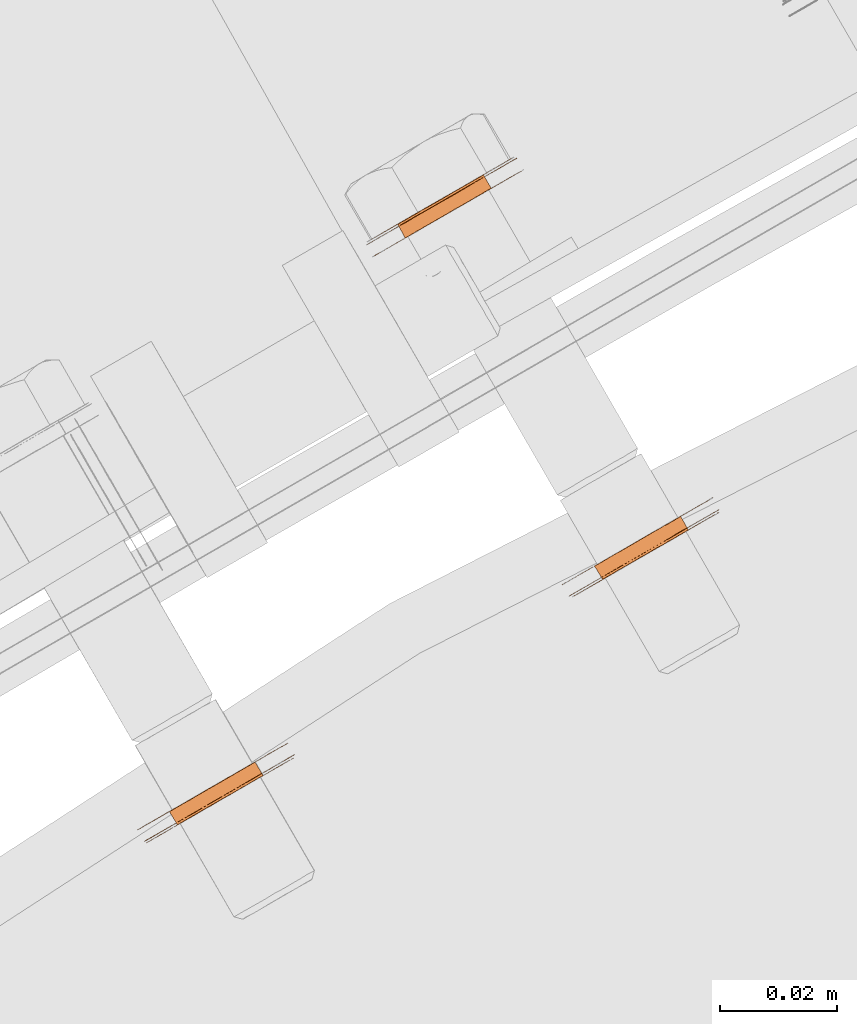
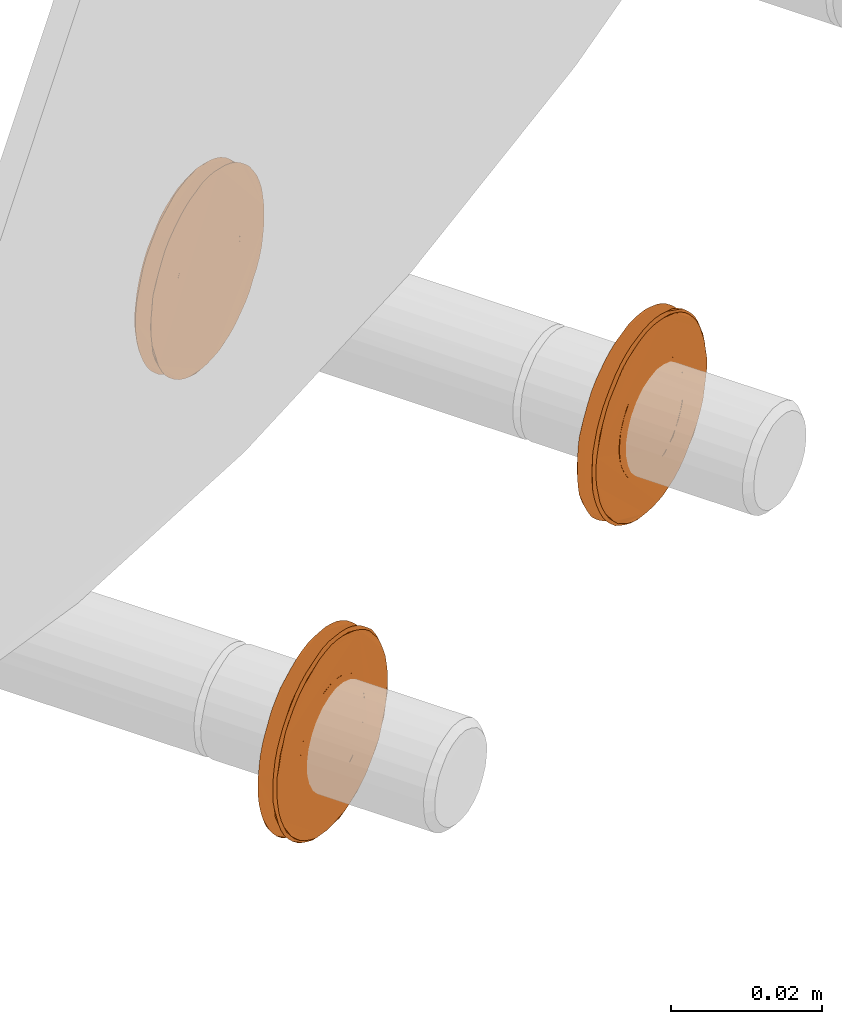
# One storey, part 112 of 126: 3 proxies.
"""IFC2X3 building model written with IfcOpenShell, lengths in millimetres."""

from ifc_helpers import new_model, si_unit, origin, origin_with_axes, place, context, project, spatial, faceted_brep, material, element, save


model = new_model("IFC2X3")

# Units and contexts
context_of_model_1 = context(None, 3, precision=0.1, world=origin())
context_of_model_2 = context(None, 3, precision=0.1, world=origin())
ifc_project = project(units=[si_unit("LENGTHUNIT", "METRE", prefix="MILLI"), si_unit("AREAUNIT", "SQUARE_METRE", prefix="CENTI"), si_unit("VOLUMEUNIT", "CUBIC_METRE", prefix="CENTI"), si_unit("MASSUNIT", "GRAM", prefix="KILO")], contexts=[context_of_model_1, context_of_model_2])

# Site, building, storey
site_placement = place(None, origin_with_axes())
site = spatial("IfcSite", under=ifc_project, at=site_placement, CompositionType="ELEMENT")
building_placement = place(site_placement, origin_with_axes())
building = spatial("IfcBuilding", under=site, at=building_placement, CompositionType="ELEMENT")
storey_placement = place(building_placement, origin_with_axes())
storey = spatial("IfcBuildingStorey", under=building, at=storey_placement, CompositionType="ELEMENT")

# Proxies
ifc_material = material(Name="STAHL")
proxy_1_placement = place(storey_placement, origin_with_axes())
element("IfcBuildingElementProxy", 1, at=proxy_1_placement, inside=storey, material=ifc_material, Name="profile", context=context_of_model_2, shape_type="Brep", body=[
    faceted_brep([(4056.4, 14928.6, 476.6), (4055.0, 14930.9, 476.6), (4056.0, 14931.5, 476.5), (4057.4, 14929.2, 476.5), (4056.4, 14928.6, 459.6), (4057.4, 14929.2, 459.7), (4056.0, 14931.5, 459.7), (4055.0, 14930.9, 459.6), (4058.4, 14929.8, 459.9), (4057.1, 14932.1, 459.9), (4059.4, 14930.3, 460.3), (4058.1, 14932.7, 460.3), (4060.3, 14930.9, 460.9), (4059.0, 14933.2, 460.9), (4061.2, 14931.3, 461.6), (4059.8, 14933.7, 461.6), (4061.9, 14931.8, 462.5), (4060.6, 14934.1, 462.5), (4062.5, 14932.1, 463.5), (4061.2, 14934.5, 463.5), (4063.0, 14932.4, 464.5), (4061.7, 14934.8, 464.5), (4063.4, 14932.6, 465.7), (4062.1, 14935.0, 465.7), (4063.6, 14932.8, 466.9), (4062.3, 14935.1, 466.9), (4063.7, 14932.8, 468.1), (4062.4, 14935.1, 468.1), (4063.6, 14932.8, 469.3), (4062.3, 14935.1, 469.3), (4063.4, 14932.6, 470.5), (4062.1, 14935.0, 470.5), (4063.0, 14932.4, 471.6), (4061.7, 14934.8, 471.6), (4062.5, 14932.1, 472.7), (4061.2, 14934.5, 472.7), (4061.9, 14931.8, 473.6), (4060.6, 14934.1, 473.6), (4061.2, 14931.3, 474.5), (4059.8, 14933.7, 474.5), (4060.3, 14930.9, 475.2), (4059.0, 14933.2, 475.2), (4059.4, 14930.3, 475.8), (4058.1, 14932.7, 475.8), (4058.4, 14929.8, 476.2), (4057.1, 14932.1, 476.2), (4043.2, 14921.4, 468.1), (4043.2, 14921.4, 469.6), (4043.4, 14921.6, 471.2), (4043.8, 14921.8, 472.7), (4044.3, 14922.1, 474.2), (4044.9, 14922.4, 475.6), (4045.6, 14922.8, 476.9), (4046.5, 14923.3, 478.1), (4047.5, 14923.9, 479.2), (4048.5, 14924.5, 480.2), (4049.7, 14925.2, 481.1), (4050.9, 14925.9, 481.8), (4052.1, 14926.6, 482.3), (4053.4, 14927.3, 482.7), (4054.8, 14928.1, 483.0), (4056.2, 14928.9, 483.1), (4057.5, 14929.7, 483.0), (4058.9, 14930.5, 482.7), (4060.2, 14931.2, 482.3), (4061.4, 14932.0, 481.8), (4062.6, 14932.7, 481.1), (4063.8, 14933.3, 480.2), (4064.8, 14933.9, 479.2), (4065.8, 14934.5, 478.1), (4066.7, 14935.0, 476.9), (4065.5, 14937.0, 476.9), (4064.7, 14936.5, 478.1), (4063.7, 14935.9, 479.2), (4062.6, 14935.3, 480.2), (4061.5, 14934.6, 481.1), (4060.3, 14933.9, 481.8), (4059.0, 14933.2, 482.3), (4057.7, 14932.5, 482.7), (4056.4, 14931.7, 483.0), (4055.0, 14930.9, 483.1), (4053.6, 14930.1, 483.0), (4052.3, 14929.3, 482.7), (4051.0, 14928.6, 482.3), (4049.7, 14927.8, 481.8), (4048.5, 14927.1, 481.1), (4047.4, 14926.5, 480.2), (4046.3, 14925.9, 479.2), (4045.3, 14925.3, 478.1), (4044.5, 14924.8, 476.9), (4043.8, 14924.4, 475.6), (4043.1, 14924.0, 474.2), (4042.6, 14923.8, 472.7), (4042.3, 14923.6, 471.2), (4042.1, 14923.4, 469.6), (4042.0, 14923.4, 468.1), (4042.1, 14923.4, 466.5), (4042.3, 14923.6, 465.0), (4042.6, 14923.8, 463.4), (4043.1, 14924.0, 462.0), (4043.8, 14924.4, 460.6), (4044.5, 14924.8, 459.3), (4045.3, 14925.3, 458.0), (4046.3, 14925.9, 456.9), (4047.4, 14926.5, 455.9), (4048.5, 14927.1, 455.1), (4049.7, 14927.8, 454.4), (4051.0, 14928.6, 453.8), (4052.3, 14929.3, 453.4), (4053.6, 14930.1, 453.2), (4055.0, 14930.9, 453.1), (4056.4, 14931.7, 453.2), (4057.7, 14932.5, 453.4), (4059.0, 14933.2, 453.8), (4060.3, 14933.9, 454.4), (4061.5, 14934.6, 455.1), (4062.6, 14935.3, 455.9), (4063.7, 14935.9, 456.9), (4064.7, 14936.5, 458.0), (4065.5, 14937.0, 459.3), (4066.3, 14937.4, 460.6), (4066.9, 14937.7, 462.0), (4067.4, 14938.0, 463.4), (4067.7, 14938.2, 465.0), (4067.9, 14938.4, 466.5), (4068.0, 14938.4, 468.1), (4067.9, 14938.4, 469.6), (4067.7, 14938.2, 471.2), (4067.4, 14938.0, 472.7), (4066.9, 14937.7, 474.2), (4066.3, 14937.4, 475.6), (4067.4, 14935.4, 475.6), (4068.0, 14935.8, 474.2), (4068.5, 14936.0, 472.7), (4068.9, 14936.2, 471.2), (4069.1, 14936.4, 469.6), (4069.1, 14936.4, 468.1), (4069.1, 14936.4, 466.5), (4068.9, 14936.2, 465.0), (4068.5, 14936.0, 463.4), (4068.0, 14935.8, 462.0), (4067.4, 14935.4, 460.6), (4066.7, 14935.0, 459.3), (4065.8, 14934.5, 458.0), (4064.8, 14933.9, 456.9), (4063.8, 14933.3, 455.9), (4062.6, 14932.7, 455.1), (4061.4, 14932.0, 454.4), (4060.2, 14931.2, 453.8), (4058.9, 14930.5, 453.4), (4057.5, 14929.7, 453.2), (4056.2, 14928.9, 453.1), (4054.8, 14928.1, 453.2), (4053.4, 14927.3, 453.4), (4052.1, 14926.6, 453.8), (4050.9, 14925.9, 454.4), (4049.7, 14925.2, 455.1), (4048.5, 14924.5, 455.9), (4047.5, 14923.9, 456.9), (4046.5, 14923.3, 458.0), (4045.6, 14922.8, 459.3), (4044.9, 14922.4, 460.6), (4044.3, 14922.1, 462.0), (4043.8, 14921.8, 463.4), (4043.4, 14921.6, 465.0), (4043.2, 14921.4, 466.5), (4043.7, 14921.3, 467.3), (4043.7, 14921.3, 468.9), (4043.9, 14921.4, 470.4), (4044.2, 14921.5, 472.0), (4044.6, 14921.8, 473.5), (4045.2, 14922.1, 474.9), (4045.9, 14922.5, 476.3), (4046.7, 14923.0, 477.5), (4047.7, 14923.5, 478.7), (4048.7, 14924.1, 479.7), (4049.8, 14924.8, 480.6), (4051.0, 14925.5, 481.3), (4052.3, 14926.2, 481.9), (4053.6, 14927.0, 482.3), (4055.0, 14927.8, 482.6), (4056.4, 14928.6, 482.7), (4057.7, 14929.3, 482.6), (4059.1, 14930.1, 482.3), (4060.4, 14930.9, 481.9), (4061.7, 14931.6, 481.3), (4062.9, 14932.3, 480.6), (4064.0, 14933.0, 479.7), (4065.0, 14933.6, 478.7), (4066.0, 14934.1, 477.5), (4066.8, 14934.6, 476.3), (4067.5, 14935.0, 474.9), (4068.1, 14935.3, 473.5), (4068.5, 14935.6, 472.0), (4068.8, 14935.8, 470.4), (4069.0, 14935.8, 468.9), (4069.0, 14935.8, 467.3), (4068.8, 14935.8, 465.7), (4068.5, 14935.6, 464.2), (4068.1, 14935.3, 462.7), (4067.5, 14935.0, 461.2), (4066.8, 14934.6, 459.9), (4066.0, 14934.1, 458.6), (4065.0, 14933.6, 457.5), (4064.0, 14933.0, 456.4), (4062.9, 14932.3, 455.6), (4061.7, 14931.6, 454.8), (4060.4, 14930.9, 454.2), (4059.1, 14930.1, 453.8), (4057.7, 14929.3, 453.6), (4056.4, 14928.6, 453.5), (4055.0, 14927.8, 453.6), (4053.6, 14927.0, 453.8), (4052.3, 14926.2, 454.2), (4051.0, 14925.5, 454.8), (4049.8, 14924.8, 455.6), (4048.7, 14924.1, 456.4), (4047.7, 14923.5, 457.5), (4046.7, 14923.0, 458.6), (4045.9, 14922.5, 459.9), (4045.2, 14922.1, 461.2), (4044.6, 14921.8, 462.7), (4044.2, 14921.5, 464.2), (4043.9, 14921.4, 465.7), (4050.8, 14925.3, 473.6), (4051.5, 14925.8, 474.5), (4052.4, 14926.3, 475.2), (4053.3, 14926.8, 475.8), (4054.3, 14927.4, 476.2), (4055.3, 14928.0, 476.5), (4055.3, 14928.0, 459.7), (4054.3, 14927.4, 459.9), (4053.3, 14926.8, 460.3), (4052.4, 14926.3, 460.9), (4051.5, 14925.8, 461.6), (4050.8, 14925.3, 462.5), (4050.2, 14925.0, 463.5), (4049.7, 14924.7, 464.5), (4049.3, 14924.5, 465.7), (4049.1, 14924.3, 466.9), (4049.0, 14924.3, 468.1), (4049.1, 14924.3, 469.3), (4049.3, 14924.5, 470.5), (4049.7, 14924.7, 471.6), (4050.2, 14925.0, 472.7), (4054.0, 14930.3, 459.7), (4054.0, 14930.3, 476.5), (4052.9, 14929.7, 476.2), (4051.9, 14929.1, 475.8), (4051.0, 14928.6, 475.2), (4050.2, 14928.1, 474.5), (4049.4, 14927.7, 473.6), (4048.8, 14927.3, 472.7), (4048.3, 14927.0, 471.6), (4047.9, 14926.8, 470.5), (4047.7, 14926.7, 469.3), (4047.6, 14926.6, 468.1), (4047.7, 14926.7, 466.9), (4047.9, 14926.8, 465.7), (4048.3, 14927.0, 464.5), (4048.8, 14927.3, 463.5), (4049.4, 14927.7, 462.5), (4050.2, 14928.1, 461.6), (4051.0, 14928.6, 460.9), (4051.9, 14929.1, 460.3), (4052.9, 14929.7, 459.9)], [[[0, 1, 2, 3]], [[4, 5, 6, 7]], [[5, 8, 9, 6]], [[8, 10, 11, 9]], [[10, 12, 13, 11]], [[12, 14, 15, 13]], [[14, 16, 17, 15]], [[16, 18, 19, 17]], [[18, 20, 21, 19]], [[20, 22, 23, 21]], [[22, 24, 25, 23]], [[24, 26, 27, 25]], [[26, 28, 29, 27]], [[28, 30, 31, 29]], [[30, 32, 33, 31]], [[32, 34, 35, 33]], [[34, 36, 37, 35]], [[36, 38, 39, 37]], [[38, 40, 41, 39]], [[40, 42, 43, 41]], [[42, 44, 45, 43]], [[44, 3, 2, 45]], [[46, 47, 48, 49, 50, 51, 52, 53, 54, 55, 56, 57, 58, 59, 60, 61, 62, 63, 64, 65, 66, 67, 68, 69, 70, 71, 72, 73, 74, 75, 76, 77, 78, 79, 80, 81, 82, 83, 84, 85, 86, 87, 88, 89, 90, 91, 92, 93, 94, 95, 96, 97, 98, 99, 100, 101, 102, 103, 104, 105, 106, 107, 108, 109, 110, 111, 112, 113, 114, 115, 116, 117, 118, 119, 120, 121, 122, 123, 124, 125, 126, 127, 128, 129, 130, 71, 70, 131, 132, 133, 134, 135, 136, 137, 138, 139, 140, 141, 142, 143, 144, 145, 146, 147, 148, 149, 150, 151, 152, 153, 154, 155, 156, 157, 158, 159, 160, 161, 162, 163, 164, 165]], [[166, 167, 168, 169, 170, 171, 172, 173, 53, 52, 51, 50, 49, 48, 47, 46, 165, 164, 163, 162, 161, 160, 159, 158, 157, 156, 155, 154, 153, 152, 151, 150, 149, 148, 147, 146, 145, 144, 143, 142, 141, 140, 139, 138, 137, 136, 135, 134, 133, 132, 131, 70, 69, 68, 67, 66, 65, 64, 63, 62, 61, 60, 59, 58, 57, 56, 55, 54, 53, 173, 174, 175, 176, 177, 178, 179, 180, 181, 182, 183, 184, 185, 186, 187, 188, 189, 190, 191, 192, 193, 194, 195, 196, 197, 198, 199, 200, 201, 202, 203, 204, 205, 206, 207, 208, 209, 210, 211, 212, 213, 214, 215, 216, 217, 218, 219, 220, 221, 222, 223]], [[167, 166, 223, 222, 221, 220, 219, 218, 217, 216, 215, 214, 213, 212, 211, 210, 209, 208, 207, 206, 205, 204, 203, 202, 201, 200, 199, 198, 197, 196, 195, 194, 193, 192, 191, 190, 189, 188, 187, 186, 185, 184, 183, 182, 181, 180, 179, 178, 177, 176, 175, 174, 173, 172, 224, 225, 226, 227, 228, 229, 0, 3, 44, 42, 40, 38, 36, 34, 32, 30, 28, 26, 24, 22, 20, 18, 16, 14, 12, 10, 8, 5, 4, 230, 231, 232, 233, 234, 235, 236, 237, 238, 239, 240, 241, 242, 243, 244, 224, 172, 171, 170, 169, 168]], [[230, 4, 7, 245]], [[0, 229, 246, 1]], [[229, 228, 247, 246]], [[228, 227, 248, 247]], [[227, 226, 249, 248]], [[226, 225, 250, 249]], [[225, 224, 251, 250]], [[224, 244, 252, 251]], [[244, 243, 253, 252]], [[243, 242, 254, 253]], [[242, 241, 255, 254]], [[241, 240, 256, 255]], [[240, 239, 257, 256]], [[239, 238, 258, 257]], [[238, 237, 259, 258]], [[237, 236, 260, 259]], [[236, 235, 261, 260]], [[235, 234, 262, 261]], [[234, 233, 263, 262]], [[233, 232, 264, 263]], [[232, 231, 265, 264]], [[231, 230, 245, 265]], [[95, 94, 93, 92, 91, 90, 89, 88, 87, 251, 252, 253, 254, 255, 256, 257, 258, 259, 260, 261, 262, 263, 264, 265, 245, 7, 6, 9, 11, 13, 15, 17, 19, 21, 23, 25, 27, 29, 31, 33, 35, 37, 39, 41, 43, 45, 2, 1, 246, 247, 248, 249, 250, 251, 87, 86, 85, 84, 83, 82, 81, 80, 79, 78, 77, 76, 75, 74, 73, 72, 71, 130, 129, 128, 127, 126, 125, 124, 123, 122, 121, 120, 119, 118, 117, 116, 115, 114, 113, 112, 111, 110, 109, 108, 107, 106, 105, 104, 103, 102, 101, 100, 99, 98, 97, 96]]]),
])
proxy_2_placement = place(storey_placement, origin_with_axes())
element("IfcBuildingElementProxy", 2, at=proxy_2_placement, inside=storey, material=ifc_material, Name="profile", context=context_of_model_2, shape_type="Brep", body=[
    faceted_brep([(4018.1, 14987.8, 475.8), (4019.4, 14985.4, 475.8), (4018.5, 14984.9, 475.2), (4017.2, 14987.2, 475.2), (4019.1, 14988.3, 476.2), (4020.4, 14986.0, 476.2), (4020.1, 14988.9, 476.5), (4021.5, 14986.6, 476.5), (4020.1, 14988.9, 459.7), (4021.5, 14986.6, 459.7), (4022.5, 14987.2, 459.6), (4021.2, 14989.5, 459.6), (4021.2, 14989.5, 476.6), (4022.5, 14987.2, 476.6), (4019.1, 14988.3, 459.9), (4020.4, 14986.0, 459.9), (4018.1, 14987.8, 460.3), (4019.4, 14985.4, 460.3), (4017.2, 14987.2, 460.9), (4018.5, 14984.9, 460.9), (4016.3, 14986.7, 461.6), (4017.7, 14984.4, 461.6), (4015.6, 14986.3, 462.5), (4016.9, 14984.0, 462.5), (4015.0, 14985.9, 463.5), (4016.3, 14983.6, 463.5), (4014.5, 14985.7, 464.5), (4015.8, 14983.3, 464.5), (4014.1, 14985.4, 465.7), (4015.4, 14983.1, 465.7), (4013.9, 14985.3, 466.9), (4015.2, 14983.0, 466.9), (4013.8, 14985.3, 468.1), (4015.1, 14982.9, 468.1), (4013.9, 14985.3, 469.3), (4015.2, 14983.0, 469.3), (4014.1, 14985.4, 470.5), (4015.4, 14983.1, 470.5), (4014.5, 14985.7, 471.6), (4015.8, 14983.3, 471.6), (4015.0, 14985.9, 472.7), (4016.3, 14983.6, 472.7), (4015.6, 14986.3, 473.6), (4016.9, 14984.0, 473.6), (4016.3, 14986.7, 474.5), (4017.7, 14984.4, 474.5), (4009.5, 14979.7, 468.1), (4009.6, 14979.7, 469.6), (4009.8, 14979.8, 471.2), (4010.1, 14980.1, 472.7), (4010.6, 14980.3, 474.2), (4011.3, 14980.7, 475.6), (4012.0, 14981.1, 476.9), (4010.8, 14983.1, 476.9), (4010.1, 14982.7, 475.6), (4009.5, 14982.3, 474.2), (4009.0, 14982.0, 472.7), (4008.6, 14981.8, 471.2), (4008.4, 14981.7, 469.6), (4008.4, 14981.7, 468.1), (4008.4, 14981.7, 466.5), (4008.6, 14981.8, 465.0), (4009.0, 14982.0, 463.4), (4009.5, 14982.3, 462.0), (4010.1, 14982.7, 460.6), (4010.8, 14983.1, 459.3), (4011.7, 14983.6, 458.0), (4012.7, 14984.2, 456.9), (4013.7, 14984.8, 455.9), (4014.9, 14985.4, 455.1), (4016.1, 14986.1, 454.4), (4017.3, 14986.9, 453.8), (4018.6, 14987.6, 453.4), (4020.0, 14988.4, 453.2), (4021.4, 14989.2, 453.1), (4022.7, 14990.0, 453.2), (4024.1, 14990.7, 453.4), (4025.4, 14991.5, 453.8), (4026.6, 14992.2, 454.4), (4027.8, 14992.9, 455.1), (4029.0, 14993.6, 455.9), (4030.0, 14994.2, 456.9), (4031.0, 14994.8, 458.0), (4031.9, 14995.2, 459.3), (4032.6, 14995.7, 460.6), (4033.2, 14996.0, 462.0), (4033.7, 14996.3, 463.4), (4034.1, 14996.5, 465.0), (4034.3, 14996.6, 466.5), (4034.3, 14996.7, 468.1), (4034.3, 14996.6, 469.6), (4034.1, 14996.5, 471.2), (4033.7, 14996.3, 472.7), (4033.2, 14996.0, 474.2), (4032.6, 14995.7, 475.6), (4031.9, 14995.2, 476.9), (4031.0, 14994.8, 478.1), (4030.0, 14994.2, 479.2), (4029.0, 14993.6, 480.2), (4027.8, 14992.9, 481.1), (4026.6, 14992.2, 481.8), (4025.4, 14991.5, 482.3), (4024.1, 14990.7, 482.7), (4022.7, 14990.0, 483.0), (4021.4, 14989.2, 483.1), (4020.0, 14988.4, 483.0), (4018.6, 14987.6, 482.7), (4017.3, 14986.9, 482.3), (4016.1, 14986.1, 481.8), (4014.9, 14985.4, 481.1), (4013.7, 14984.8, 480.2), (4012.7, 14984.2, 479.2), (4011.7, 14983.6, 478.1), (4012.8, 14981.6, 478.1), (4013.8, 14982.2, 479.2), (4014.9, 14982.8, 480.2), (4016.0, 14983.4, 481.1), (4017.2, 14984.1, 481.8), (4018.5, 14984.9, 482.3), (4019.8, 14985.6, 482.7), (4021.1, 14986.4, 483.0), (4022.5, 14987.2, 483.1), (4023.9, 14988.0, 483.0), (4025.2, 14988.7, 482.7), (4026.5, 14989.5, 482.3), (4027.8, 14990.2, 481.8), (4029.0, 14990.9, 481.1), (4030.1, 14991.6, 480.2), (4031.2, 14992.2, 479.2), (4032.2, 14992.8, 478.1), (4033.0, 14993.3, 476.9), (4033.8, 14993.7, 475.6), (4034.4, 14994.0, 474.2), (4034.9, 14994.3, 472.7), (4035.2, 14994.5, 471.2), (4035.4, 14994.6, 469.6), (4035.5, 14994.7, 468.1), (4035.4, 14994.6, 466.5), (4035.2, 14994.5, 465.0), (4034.9, 14994.3, 463.4), (4034.4, 14994.0, 462.0), (4033.8, 14993.7, 460.6), (4033.0, 14993.3, 459.3), (4032.2, 14992.8, 458.0), (4031.2, 14992.2, 456.9), (4030.1, 14991.6, 455.9), (4029.0, 14990.9, 455.1), (4027.8, 14990.2, 454.4), (4026.5, 14989.5, 453.8), (4025.2, 14988.7, 453.4), (4023.9, 14988.0, 453.2), (4022.5, 14987.2, 453.1), (4021.1, 14986.4, 453.2), (4019.8, 14985.6, 453.4), (4018.5, 14984.9, 453.8), (4017.2, 14984.1, 454.4), (4016.0, 14983.4, 455.1), (4014.9, 14982.8, 455.9), (4013.8, 14982.2, 456.9), (4012.8, 14981.6, 458.0), (4012.0, 14981.1, 459.3), (4011.3, 14980.7, 460.6), (4010.6, 14980.3, 462.0), (4010.1, 14980.1, 463.4), (4009.8, 14979.8, 465.0), (4009.6, 14979.7, 466.5), (4030.8, 14995.1, 477.5), (4029.8, 14994.5, 478.7), (4028.8, 14993.9, 479.7), (4027.7, 14993.3, 480.6), (4026.5, 14992.6, 481.3), (4025.2, 14991.9, 481.9), (4023.9, 14991.1, 482.3), (4022.5, 14990.3, 482.6), (4021.2, 14989.5, 482.7), (4019.8, 14988.7, 482.6), (4018.4, 14988.0, 482.3), (4017.1, 14987.2, 481.9), (4015.8, 14986.5, 481.3), (4014.6, 14985.8, 480.6), (4013.5, 14985.1, 479.7), (4012.5, 14984.5, 478.7), (4011.5, 14984.0, 477.5), (4010.7, 14983.5, 476.3), (4010.0, 14983.1, 474.9), (4009.4, 14982.7, 473.5), (4009.0, 14982.5, 472.0), (4008.7, 14982.3, 470.4), (4008.5, 14982.2, 468.9), (4008.5, 14982.2, 467.3), (4008.7, 14982.3, 465.7), (4009.0, 14982.5, 464.2), (4009.4, 14982.7, 462.7), (4010.0, 14983.1, 461.2), (4010.7, 14983.5, 459.9), (4011.5, 14984.0, 458.6), (4012.5, 14984.5, 457.5), (4013.5, 14985.1, 456.4), (4014.6, 14985.8, 455.6), (4015.8, 14986.5, 454.8), (4017.1, 14987.2, 454.2), (4018.4, 14988.0, 453.8), (4019.8, 14988.7, 453.6), (4021.2, 14989.5, 453.5), (4022.5, 14990.3, 453.6), (4023.9, 14991.1, 453.8), (4025.2, 14991.9, 454.2), (4026.5, 14992.6, 454.8), (4027.7, 14993.3, 455.6), (4028.8, 14993.9, 456.4), (4029.8, 14994.5, 457.5), (4030.8, 14995.1, 458.6), (4031.6, 14995.6, 459.9), (4032.3, 14996.0, 461.2), (4032.9, 14996.3, 462.7), (4033.3, 14996.6, 464.2), (4033.6, 14996.7, 465.7), (4033.8, 14996.8, 467.3), (4033.8, 14996.8, 468.9), (4033.6, 14996.7, 470.4), (4033.3, 14996.6, 472.0), (4032.9, 14996.3, 473.5), (4032.3, 14996.0, 474.9), (4031.6, 14995.6, 476.3), (4026.7, 14992.7, 473.6), (4026.0, 14992.3, 474.5), (4025.1, 14991.8, 475.2), (4024.2, 14991.3, 475.8), (4023.2, 14990.7, 476.2), (4022.2, 14990.1, 476.5), (4022.2, 14990.1, 459.7), (4023.2, 14990.7, 459.9), (4024.2, 14991.3, 460.3), (4025.1, 14991.8, 460.9), (4026.0, 14992.3, 461.6), (4026.7, 14992.7, 462.5), (4027.3, 14993.1, 463.5), (4027.8, 14993.4, 464.5), (4028.2, 14993.6, 465.7), (4028.4, 14993.7, 466.9), (4028.5, 14993.8, 468.1), (4028.4, 14993.7, 469.3), (4028.2, 14993.6, 470.5), (4027.8, 14993.4, 471.6), (4027.3, 14993.1, 472.7), (4023.5, 14987.8, 459.7), (4023.5, 14987.8, 476.5), (4024.6, 14988.4, 476.2), (4025.6, 14989.0, 475.8), (4026.5, 14989.5, 475.2), (4027.3, 14990.0, 474.5), (4028.1, 14990.4, 473.6), (4028.7, 14990.8, 472.7), (4029.2, 14991.1, 471.6), (4029.6, 14991.3, 470.5), (4029.8, 14991.4, 469.3), (4029.9, 14991.4, 468.1), (4029.8, 14991.4, 466.9), (4029.6, 14991.3, 465.7), (4029.2, 14991.1, 464.5), (4028.7, 14990.8, 463.5), (4028.1, 14990.4, 462.5), (4027.3, 14990.0, 461.6), (4026.5, 14989.5, 460.9), (4025.6, 14989.0, 460.3), (4024.6, 14988.4, 459.9)], [[[0, 1, 2, 3]], [[4, 5, 1, 0]], [[6, 7, 5, 4]], [[8, 9, 10, 11]], [[12, 13, 7, 6]], [[14, 15, 9, 8]], [[16, 17, 15, 14]], [[18, 19, 17, 16]], [[20, 21, 19, 18]], [[22, 23, 21, 20]], [[24, 25, 23, 22]], [[26, 27, 25, 24]], [[28, 29, 27, 26]], [[30, 31, 29, 28]], [[32, 33, 31, 30]], [[34, 35, 33, 32]], [[36, 37, 35, 34]], [[38, 39, 37, 36]], [[40, 41, 39, 38]], [[42, 43, 41, 40]], [[44, 45, 43, 42]], [[3, 2, 45, 44]], [[46, 47, 48, 49, 50, 51, 52, 53, 54, 55, 56, 57, 58, 59, 60, 61, 62, 63, 64, 65, 66, 67, 68, 69, 70, 71, 72, 73, 74, 75, 76, 77, 78, 79, 80, 81, 82, 83, 84, 85, 86, 87, 88, 89, 90, 91, 92, 93, 94, 95, 96, 97, 98, 99, 100, 101, 102, 103, 104, 105, 106, 107, 108, 109, 110, 111, 112, 53, 52, 113, 114, 115, 116, 117, 118, 119, 120, 121, 122, 123, 124, 125, 126, 127, 128, 129, 130, 131, 132, 133, 134, 135, 136, 137, 138, 139, 140, 141, 142, 143, 144, 145, 146, 147, 148, 149, 150, 151, 152, 153, 154, 155, 156, 157, 158, 159, 160, 161, 162, 163, 164, 165]], [[59, 58, 57, 56, 55, 54, 53, 112, 111, 110, 109, 108, 107, 106, 105, 104, 103, 102, 101, 100, 99, 98, 97, 96, 166, 167, 168, 169, 170, 171, 172, 173, 174, 175, 176, 177, 178, 179, 180, 181, 182, 183, 184, 185, 186, 187, 188, 189, 190, 191, 192, 193, 194, 195, 196, 197, 198, 199, 200, 201, 202, 203, 204, 205, 206, 207, 208, 209, 210, 211, 212, 213, 214, 215, 216, 217, 218, 219, 220, 221, 222, 223, 166, 96, 95, 94, 93, 92, 91, 90, 89, 88, 87, 86, 85, 84, 83, 82, 81, 80, 79, 78, 77, 76, 75, 74, 73, 72, 71, 70, 69, 68, 67, 66, 65, 64, 63, 62, 61, 60]], [[189, 188, 187, 186, 185, 184, 183, 182, 181, 180, 179, 178, 177, 176, 175, 174, 173, 172, 171, 170, 169, 168, 167, 166, 223, 224, 225, 226, 227, 228, 229, 12, 6, 4, 0, 3, 44, 42, 40, 38, 36, 34, 32, 30, 28, 26, 24, 22, 20, 18, 16, 14, 8, 11, 230, 231, 232, 233, 234, 235, 236, 237, 238, 239, 240, 241, 242, 243, 244, 224, 223, 222, 221, 220, 219, 218, 217, 216, 215, 214, 213, 212, 211, 210, 209, 208, 207, 206, 205, 204, 203, 202, 201, 200, 199, 198, 197, 196, 195, 194, 193, 192, 191, 190]], [[230, 11, 10, 245]], [[12, 229, 246, 13]], [[229, 228, 247, 246]], [[228, 227, 248, 247]], [[227, 226, 249, 248]], [[226, 225, 250, 249]], [[225, 224, 251, 250]], [[224, 244, 252, 251]], [[244, 243, 253, 252]], [[243, 242, 254, 253]], [[242, 241, 255, 254]], [[241, 240, 256, 255]], [[240, 239, 257, 256]], [[239, 238, 258, 257]], [[238, 237, 259, 258]], [[237, 236, 260, 259]], [[236, 235, 261, 260]], [[235, 234, 262, 261]], [[234, 233, 263, 262]], [[233, 232, 264, 263]], [[232, 231, 265, 264]], [[231, 230, 245, 265]], [[46, 165, 164, 163, 162, 161, 160, 159, 158, 157, 156, 155, 154, 153, 152, 151, 150, 149, 148, 147, 146, 145, 144, 143, 142, 141, 140, 139, 138, 137, 136, 135, 134, 133, 132, 131, 130, 129, 128, 251, 252, 253, 254, 255, 256, 257, 258, 259, 260, 261, 262, 263, 264, 265, 245, 10, 9, 15, 17, 19, 21, 23, 25, 27, 29, 31, 33, 35, 37, 39, 41, 43, 45, 2, 1, 5, 7, 13, 246, 247, 248, 249, 250, 251, 128, 127, 126, 125, 124, 123, 122, 121, 120, 119, 118, 117, 116, 115, 114, 113, 52, 51, 50, 49, 48, 47]]]),
])
proxy_3_placement = place(storey_placement, origin_with_axes())
element("IfcBuildingElementProxy", 3, at=proxy_3_placement, inside=storey, material=ifc_material, Name="profile", context=context_of_model_2, shape_type="Brep", body=[
    faceted_brep([(3986.8, 14888.4, 475.6), (3985.4, 14890.7, 475.6), (3986.3, 14891.2, 475.0), (3987.7, 14888.9, 475.0), (3981.9, 14885.6, 459.7), (3983.0, 14886.2, 459.6), (3981.6, 14888.5, 459.6), (3980.6, 14887.9, 459.7), (3985.8, 14887.8, 476.1), (3984.4, 14890.2, 476.1), (3984.8, 14887.2, 476.4), (3983.4, 14889.6, 476.4), (3984.0, 14886.8, 459.6), (3982.7, 14889.1, 459.6), (3985.0, 14887.4, 459.8), (3983.7, 14889.7, 459.8), (3986.0, 14888.0, 460.2), (3984.7, 14890.3, 460.2), (3987.0, 14888.5, 460.7), (3985.6, 14890.8, 460.7), (3987.9, 14889.0, 461.4), (3986.5, 14891.4, 461.4), (3988.6, 14889.5, 462.2), (3987.3, 14891.8, 462.2), (3989.3, 14889.9, 463.1), (3988.0, 14892.2, 463.1), (3989.9, 14890.2, 464.1), (3988.5, 14892.5, 464.1), (3990.3, 14890.4, 465.2), (3988.9, 14892.8, 465.2), (3990.6, 14890.6, 466.4), (3989.2, 14892.9, 466.4), (3990.7, 14890.7, 467.6), (3989.3, 14893.0, 467.6), (3990.7, 14890.6, 468.8), (3989.3, 14893.0, 468.8), (3990.5, 14890.5, 470.0), (3989.2, 14892.9, 470.0), (3990.2, 14890.4, 471.2), (3988.8, 14892.7, 471.2), (3989.7, 14890.1, 472.3), (3988.4, 14892.4, 472.3), (3989.2, 14889.8, 473.3), (3987.8, 14892.1, 473.3), (3988.5, 14889.4, 474.2), (3987.1, 14891.7, 474.2), (3970.2, 14879.3, 467.9), (3970.2, 14879.3, 469.4), (3970.4, 14879.4, 471.0), (3970.7, 14879.6, 472.5), (3971.2, 14879.9, 474.0), (3971.8, 14880.2, 475.4), (3972.5, 14880.6, 476.7), (3973.4, 14881.1, 478.0), (3974.3, 14881.7, 479.1), (3975.4, 14882.3, 480.1), (3976.5, 14882.9, 481.0), (3977.7, 14883.6, 481.7), (3979.0, 14884.3, 482.3), (3980.3, 14885.1, 482.7), (3981.6, 14885.9, 483.0), (3983.0, 14886.7, 483.1), (3984.3, 14887.4, 483.0), (3985.7, 14888.2, 482.8), (3987.0, 14889.0, 482.4), (3988.3, 14889.7, 481.9), (3989.5, 14890.4, 481.2), (3990.6, 14891.1, 480.3), (3991.7, 14891.7, 479.3), (3992.7, 14892.3, 478.3), (3993.6, 14892.8, 477.0), (3994.3, 14893.2, 475.7), (3994.9, 14893.6, 474.4), (3995.5, 14893.9, 472.9), (3995.8, 14894.1, 471.4), (3994.9, 14896.2, 469.8), (3994.7, 14896.1, 471.4), (3994.3, 14895.8, 472.9), (3993.8, 14895.6, 474.4), (3993.2, 14895.2, 475.7), (3992.4, 14894.8, 477.0), (3991.5, 14894.3, 478.3), (3990.6, 14893.7, 479.3), (3989.5, 14893.1, 480.3), (3988.3, 14892.4, 481.2), (3987.1, 14891.7, 481.9), (3985.9, 14891.0, 482.4), (3984.5, 14890.2, 482.8), (3983.2, 14889.4, 483.0), (3981.8, 14888.6, 483.1), (3980.5, 14887.9, 483.0), (3979.1, 14887.1, 482.7), (3977.8, 14886.3, 482.3), (3976.6, 14885.6, 481.7), (3975.4, 14884.9, 481.0), (3974.2, 14884.3, 480.1), (3973.2, 14883.7, 479.1), (3972.2, 14883.1, 478.0), (3971.4, 14882.6, 476.7), (3970.7, 14882.2, 475.4), (3970.1, 14881.9, 474.0), (3969.6, 14881.6, 472.5), (3969.3, 14881.4, 471.0), (3969.1, 14881.3, 469.4), (3969.0, 14881.2, 467.9), (3969.1, 14881.3, 466.3), (3969.3, 14881.4, 464.8), (3969.7, 14881.6, 463.2), (3970.2, 14881.9, 461.8), (3970.8, 14882.3, 460.4), (3971.6, 14882.7, 459.1), (3972.5, 14883.2, 457.9), (3973.4, 14883.8, 456.8), (3974.5, 14884.4, 455.8), (3975.7, 14885.1, 455.0), (3976.9, 14885.8, 454.3), (3978.1, 14886.5, 453.7), (3979.5, 14887.3, 453.4), (3980.8, 14888.1, 453.1), (3982.2, 14888.8, 453.1), (3983.5, 14889.6, 453.2), (3984.9, 14890.4, 453.4), (3986.2, 14891.2, 453.9), (3987.4, 14891.9, 454.4), (3988.6, 14892.6, 455.2), (3989.8, 14893.2, 456.1), (3990.8, 14893.8, 457.1), (3991.8, 14894.4, 458.2), (3992.6, 14894.9, 459.4), (3993.3, 14895.3, 460.7), (3993.9, 14895.6, 462.1), (3994.4, 14895.9, 463.6), (3994.7, 14896.1, 465.1), (3994.9, 14896.2, 466.7), (3995.0, 14896.2, 468.3), (3996.0, 14894.2, 469.8), (3996.1, 14894.3, 468.3), (3996.1, 14894.2, 466.7), (3995.9, 14894.1, 465.1), (3995.6, 14893.9, 463.6), (3995.1, 14893.6, 462.1), (3994.5, 14893.3, 460.7), (3993.8, 14892.9, 459.4), (3992.9, 14892.4, 458.2), (3992.0, 14891.8, 457.1), (3990.9, 14891.2, 456.1), (3989.8, 14890.6, 455.2), (3988.6, 14889.9, 454.4), (3987.3, 14889.2, 453.9), (3986.0, 14888.4, 453.4), (3984.7, 14887.6, 453.2), (3983.3, 14886.9, 453.1), (3982.0, 14886.1, 453.1), (3980.6, 14885.3, 453.4), (3979.3, 14884.5, 453.7), (3978.0, 14883.8, 454.3), (3976.8, 14883.1, 455.0), (3975.7, 14882.4, 455.8), (3974.6, 14881.8, 456.8), (3973.6, 14881.2, 457.9), (3972.7, 14880.7, 459.1), (3972.0, 14880.3, 460.4), (3971.4, 14879.9, 461.8), (3970.8, 14879.7, 463.2), (3970.5, 14879.4, 464.8), (3970.2, 14879.3, 466.3), (3970.7, 14879.1, 468.6), (3970.8, 14879.2, 470.1), (3971.1, 14879.3, 471.7), (3971.5, 14879.6, 473.2), (3972.1, 14879.9, 474.6), (3972.7, 14880.3, 476.0), (3973.5, 14880.7, 477.3), (3974.5, 14881.3, 478.5), (3975.5, 14881.9, 479.5), (3976.6, 14882.5, 480.4), (3977.8, 14883.2, 481.2), (3979.1, 14883.9, 481.8), (3980.4, 14884.7, 482.3), (3981.7, 14885.5, 482.5), (3983.1, 14886.3, 482.7), (3984.5, 14887.1, 482.6), (3985.8, 14887.8, 482.4), (3987.1, 14888.6, 482.0), (3988.4, 14889.3, 481.4), (3989.6, 14890.0, 480.7), (3990.8, 14890.7, 479.9), (3991.9, 14891.3, 478.9), (3992.8, 14891.9, 477.7), (3993.7, 14892.4, 476.5), (3994.4, 14892.8, 475.2), (3995.0, 14893.1, 473.7), (3995.5, 14893.4, 472.3), (3995.8, 14893.6, 470.7), (3996.0, 14893.7, 469.2), (3996.0, 14893.7, 467.6), (3995.9, 14893.6, 466.0), (3995.6, 14893.5, 464.5), (3995.2, 14893.2, 462.9), (3994.6, 14892.9, 461.5), (3994.0, 14892.5, 460.1), (3993.2, 14892.1, 458.8), (3992.2, 14891.5, 457.7), (3991.2, 14890.9, 456.6), (3990.1, 14890.3, 455.7), (3988.9, 14889.6, 454.9), (3987.6, 14888.9, 454.3), (3986.3, 14888.1, 453.9), (3985.0, 14887.3, 453.6), (3983.6, 14886.6, 453.5), (3982.2, 14885.8, 453.5), (3980.9, 14885.0, 453.8), (3979.6, 14884.2, 454.1), (3978.3, 14883.5, 454.7), (3977.1, 14882.8, 455.4), (3975.9, 14882.1, 456.3), (3974.8, 14881.5, 457.3), (3973.9, 14880.9, 458.4), (3973.0, 14880.5, 459.6), (3972.3, 14880.0, 461.0), (3971.7, 14879.7, 462.4), (3971.2, 14879.4, 463.9), (3970.9, 14879.2, 465.4), (3970.7, 14879.1, 467.0), (3978.8, 14883.8, 474.8), (3979.7, 14884.3, 475.5), (3980.7, 14884.9, 476.0), (3981.7, 14885.4, 476.3), (3982.7, 14886.0, 476.5), (3983.7, 14886.6, 476.6), (3980.9, 14885.0, 460.1), (3979.9, 14884.4, 460.5), (3979.0, 14883.9, 461.2), (3978.2, 14883.5, 462.0), (3977.5, 14883.1, 462.9), (3977.0, 14882.7, 463.9), (3976.5, 14882.5, 465.0), (3976.2, 14882.3, 466.1), (3976.0, 14882.2, 467.3), (3976.0, 14882.2, 468.5), (3976.1, 14882.2, 469.7), (3976.4, 14882.4, 470.9), (3976.8, 14882.6, 472.0), (3977.4, 14883.0, 473.0), (3978.1, 14883.4, 474.0), (3977.7, 14886.3, 461.2), (3976.9, 14885.8, 462.0), (3978.6, 14886.8, 460.5), (3979.6, 14887.3, 460.1), (3982.4, 14889.0, 476.6), (3981.3, 14888.4, 476.5), (3980.3, 14887.8, 476.3), (3979.3, 14887.2, 476.0), (3978.4, 14886.6, 475.5), (3977.5, 14886.1, 474.8), (3976.7, 14885.7, 474.0), (3976.0, 14885.3, 473.0), (3975.5, 14885.0, 472.0), (3975.1, 14884.7, 470.9), (3974.8, 14884.6, 469.7), (3974.6, 14884.5, 468.5), (3974.7, 14884.5, 467.3), (3974.8, 14884.6, 466.1), (3975.1, 14884.8, 465.0), (3975.6, 14885.1, 463.9), (3976.2, 14885.4, 462.9)], [[[0, 1, 2, 3]], [[4, 5, 6, 7]], [[8, 9, 1, 0]], [[10, 11, 9, 8]], [[5, 12, 13, 6]], [[12, 14, 15, 13]], [[14, 16, 17, 15]], [[18, 19, 17, 16]], [[20, 21, 19, 18]], [[22, 23, 21, 20]], [[24, 25, 23, 22]], [[26, 27, 25, 24]], [[28, 29, 27, 26]], [[30, 31, 29, 28]], [[32, 33, 31, 30]], [[34, 35, 33, 32]], [[36, 37, 35, 34]], [[38, 39, 37, 36]], [[40, 41, 39, 38]], [[42, 43, 41, 40]], [[44, 45, 43, 42]], [[3, 2, 45, 44]], [[46, 47, 48, 49, 50, 51, 52, 53, 54, 55, 56, 57, 58, 59, 60, 61, 62, 63, 64, 65, 66, 67, 68, 69, 70, 71, 72, 73, 74, 75, 76, 77, 78, 79, 80, 81, 82, 83, 84, 85, 86, 87, 88, 89, 90, 91, 92, 93, 94, 95, 96, 97, 98, 99, 100, 101, 102, 103, 104, 105, 106, 107, 108, 109, 110, 111, 112, 113, 114, 115, 116, 117, 118, 119, 120, 121, 122, 123, 124, 125, 126, 127, 128, 129, 130, 131, 132, 133, 134, 75, 74, 135, 136, 137, 138, 139, 140, 141, 142, 143, 144, 145, 146, 147, 148, 149, 150, 151, 152, 153, 154, 155, 156, 157, 158, 159, 160, 161, 162, 163, 164, 165]], [[166, 167, 168, 169, 170, 171, 172, 173, 174, 55, 54, 53, 52, 51, 50, 49, 48, 47, 46, 165, 164, 163, 162, 161, 160, 159, 158, 157, 156, 155, 154, 153, 152, 151, 150, 149, 148, 147, 146, 145, 144, 143, 142, 141, 140, 139, 138, 137, 136, 135, 74, 73, 72, 71, 70, 69, 68, 67, 66, 65, 64, 63, 62, 61, 60, 59, 58, 57, 56, 55, 174, 175, 176, 177, 178, 179, 180, 181, 182, 183, 184, 185, 186, 187, 188, 189, 190, 191, 192, 193, 194, 195, 196, 197, 198, 199, 200, 201, 202, 203, 204, 205, 206, 207, 208, 209, 210, 211, 212, 213, 214, 215, 216, 217, 218, 219, 220, 221, 222, 223]], [[166, 223, 222, 221, 220, 219, 218, 217, 216, 215, 214, 213, 212, 211, 210, 209, 208, 207, 206, 205, 204, 203, 202, 201, 200, 199, 198, 197, 196, 195, 194, 193, 192, 191, 190, 189, 188, 187, 186, 185, 184, 183, 182, 181, 180, 179, 178, 177, 176, 175, 174, 173, 224, 225, 226, 227, 228, 229, 10, 8, 0, 3, 44, 42, 40, 38, 36, 34, 32, 30, 28, 26, 24, 22, 20, 18, 16, 14, 12, 5, 4, 230, 231, 232, 233, 234, 235, 236, 237, 238, 239, 240, 241, 242, 243, 244, 224, 173, 172, 171, 170, 169, 168, 167]], [[232, 245, 246, 233]], [[231, 247, 245, 232]], [[230, 248, 247, 231]], [[229, 249, 11, 10]], [[4, 7, 248, 230]], [[228, 250, 249, 229]], [[227, 251, 250, 228]], [[226, 252, 251, 227]], [[225, 253, 252, 226]], [[224, 254, 253, 225]], [[244, 255, 254, 224]], [[243, 256, 255, 244]], [[242, 257, 256, 243]], [[241, 258, 257, 242]], [[240, 259, 258, 241]], [[239, 260, 259, 240]], [[238, 261, 260, 239]], [[237, 262, 261, 238]], [[236, 263, 262, 237]], [[235, 264, 263, 236]], [[234, 265, 264, 235]], [[233, 246, 265, 234]], [[104, 103, 102, 101, 100, 99, 98, 97, 96, 95, 94, 93, 253, 254, 255, 256, 257, 258, 259, 260, 261, 262, 263, 264, 265, 246, 245, 247, 248, 7, 6, 13, 15, 17, 19, 21, 23, 25, 27, 29, 31, 33, 35, 37, 39, 41, 43, 45, 2, 1, 9, 11, 249, 250, 251, 252, 253, 93, 92, 91, 90, 89, 88, 87, 86, 85, 84, 83, 82, 81, 80, 79, 78, 77, 76, 75, 134, 133, 132, 131, 130, 129, 128, 127, 126, 125, 124, 123, 122, 121, 120, 119, 118, 117, 116, 115, 114, 113, 112, 111, 110, 109, 108, 107, 106, 105]]]),
])

save(model, "model.ifc")
